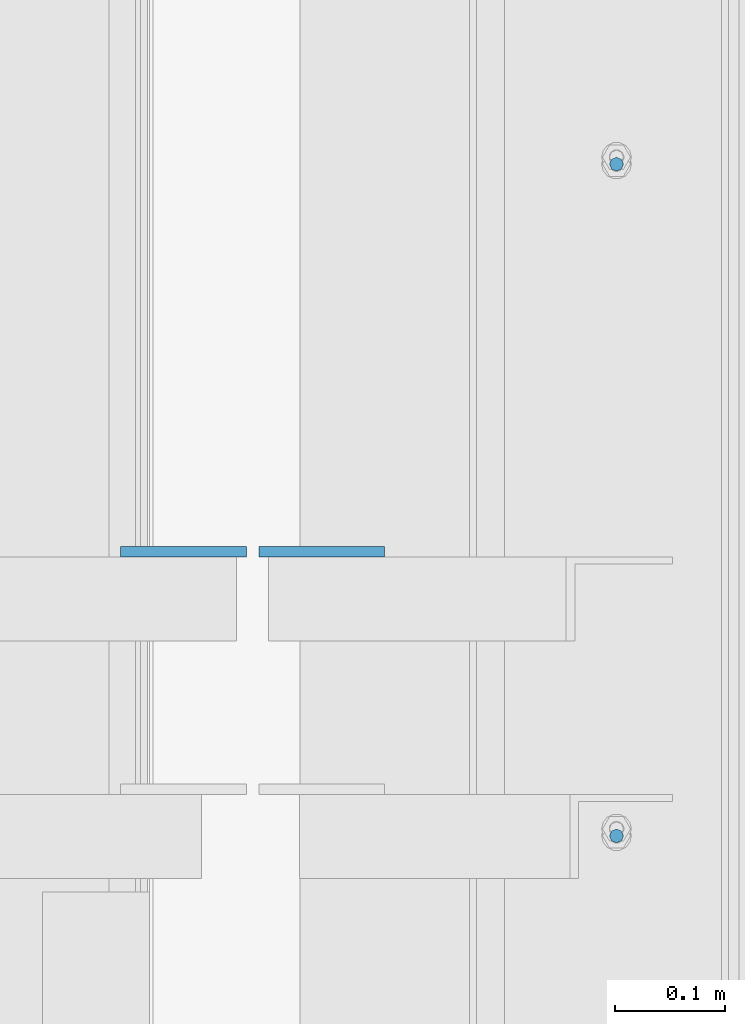
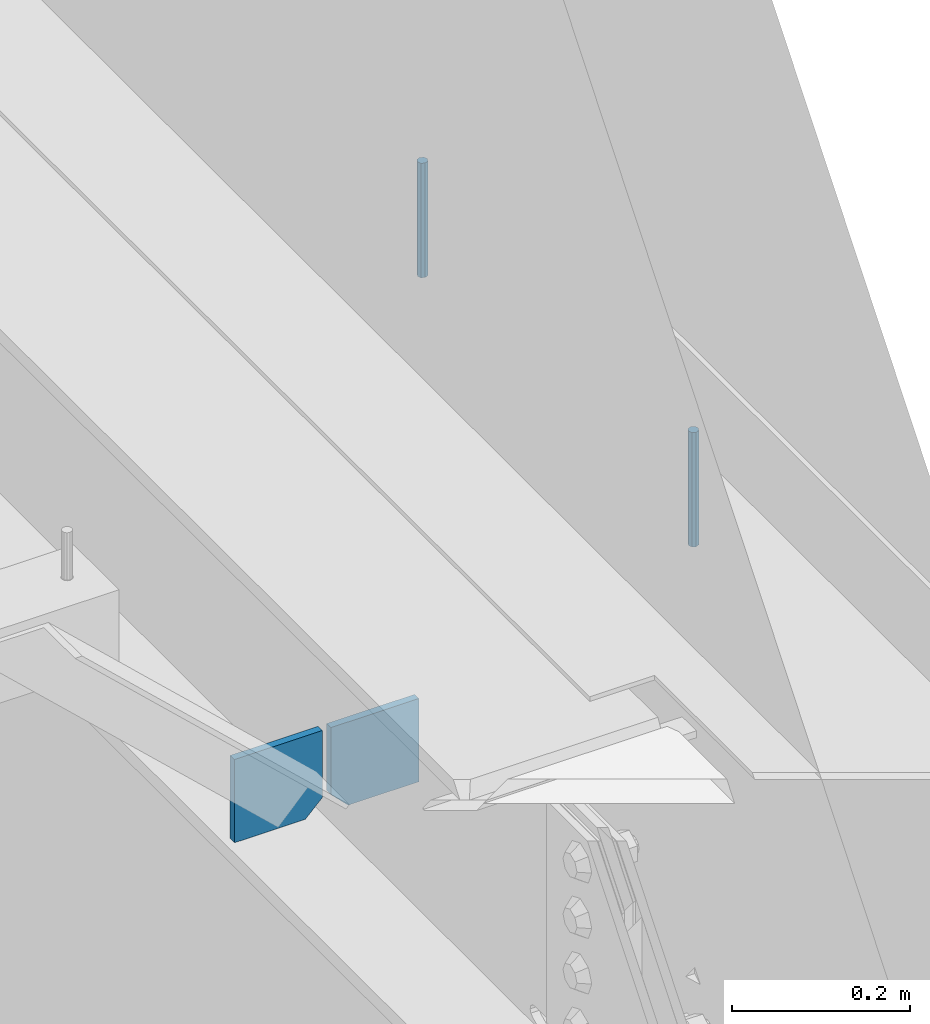
# One storey, part 471 of 1179: 4 columns, 1 element without a shape of its own.
"""IFC2X3 building model written with IfcOpenShell, lengths in millimetres."""

from ifc_helpers import new_model, si_unit, frame, origin_with_axes, place, context, subcontext, project, spatial, faceted_brep, material, type_object, element, aggregate, save


model = new_model("IFC2X3")

# Units and contexts
model_context = context("Model", 3, precision=1e-05, world=origin_with_axes())
body_context = subcontext(model_context, "Body", "Model", "MODEL_VIEW")
ifc_project = project(units=[si_unit("LENGTHUNIT", "METRE", prefix="MILLI"), si_unit("AREAUNIT", "SQUARE_METRE"), si_unit("VOLUMEUNIT", "CUBIC_METRE"), si_unit("MASSUNIT", "GRAM", prefix="KILO"), si_unit("TIMEUNIT", "SECOND"), si_unit("PLANEANGLEUNIT", "RADIAN"), si_unit("SOLIDANGLEUNIT", "STERADIAN"), si_unit("THERMODYNAMICTEMPERATUREUNIT", "DEGREE_CELSIUS"), si_unit("LUMINOUSINTENSITYUNIT", "LUMEN")], contexts=[model_context])

# Site, building, storey
site_placement = place(None, origin_with_axes())
site = spatial("IfcSite", under=ifc_project, at=site_placement, CompositionType="ELEMENT")
building_placement = place(site_placement, origin_with_axes())
building = spatial("IfcBuilding", under=site, at=building_placement, Name="Undefined", CompositionType="ELEMENT")
storey_placement = place(building_placement, origin_with_axes())
storey = spatial("IfcBuildingStorey", under=building, at=storey_placement, Name="Undefined", CompositionType="ELEMENT", Elevation=0.0)

# Assembly, columns
assembly_placement = place(storey_placement, origin_with_axes())
assembly = element("IfcElementAssembly", 1, at=assembly_placement, inside=storey, Name="BEAM", AssemblyPlace="NOTDEFINED", PredefinedType="RIGID_FRAME")
ifc_material_1 = material(Name="STEEL/A36")
column_type_1 = type_object("IfcColumnType", PredefinedType="NOTDEFINED")
column_1_placement = place(assembly_placement, frame((24245.09375, 28235.9541453824, 3702.05), z_axis=(1.0, 0.0, 0.0), x_axis=(0.0, 0.0, 1.0)))
column_1 = element("IfcColumn", 2, at=column_1_placement, type_object=column_type_1, material=ifc_material_1, Name="PLATE", context=body_context, shape_type="Brep", body=[
    faceted_brep([(22.2250000000004, 4.76250000000073, 57.1500000000015), (0.0, 4.76250000000073, 34.9249999999993), (0.0, -4.76250000000073, 34.9249999999993), (22.2250000000004, -4.76250000000073, 57.1500000000015), (114.300000000001, 4.76250000000073, 57.1500000000015), (114.300000000001, 4.76250000000073, -57.1500000000015), (0.0, 4.76250000000073, -57.1500000000015), (114.300000000001, -4.76250000000073, 57.1500000000015), (0.0, -4.76250000000073, -57.1500000000015), (114.300000000001, -4.76250000000073, -57.1500000000015)], [[[0, 1, 2, 3]], [[4, 5, 6, 1, 0]], [[7, 4, 0, 3]], [[8, 9, 7, 3, 2]], [[8, 6, 5, 9]], [[7, 9, 5, 4]], [[6, 8, 2, 1]]]),
])
column_2_placement = place(assembly_placement, frame((24370.50625, 28235.9541453824, 3702.05), z_axis=(-1.0, 0.0, 0.0), x_axis=(0.0, 0.0, 1.0)))
column_2 = element("IfcColumn", 3, at=column_2_placement, type_object=column_type_1, material=ifc_material_1, Name="PLATE", context=body_context, shape_type="Brep", body=[
    faceted_brep([(22.2250000000004, 4.76250000000073, 57.1500000000015), (0.0, 4.76250000000073, 34.9249999999993), (0.0, -4.76250000000073, 34.9249999999993), (22.2250000000004, -4.76250000000073, 57.1500000000015), (114.300000000001, 4.76250000000073, 57.1500000000015), (114.300000000001, 4.76250000000073, -57.1500000000015), (0.0, 4.76250000000073, -57.1500000000015), (114.300000000001, -4.76250000000073, 57.1500000000015), (0.0, -4.76250000000073, -57.1500000000015), (114.300000000001, -4.76250000000073, -57.1500000000015)], [[[0, 1, 2, 3]], [[4, 5, 6, 1, 0]], [[7, 4, 0, 3]], [[8, 9, 7, 3, 2]], [[8, 6, 5, 9]], [[7, 9, 5, 4]], [[6, 8, 2, 1]]]),
])
ifc_material_2 = material(Name="STEEL/A307")
column_type_2 = type_object("IfcColumnType", PredefinedType="NOTDEFINED")
column_3_placement = place(assembly_placement, frame((24638.0, 28587.70025, 4108.45), z_axis=(0.0, 1.0, 0.0), x_axis=(0.0, 0.0, 1.0)))
column_3 = element("IfcColumn", 4, at=column_3_placement, type_object=column_type_2, material=ifc_material_2, Name="THREADED ROD", context=body_context, shape_type="Brep", body=[
    faceted_brep([(0.0, -6.34999999999854, 0.0), (0.0, -4.49012806053361, -4.49012806053452), (157.162499999999, -4.49012806053361, -4.49012806053361), (157.162499999999, -6.34999999999854, 0.0), (0.0, 0.0, -6.34999999999991), (157.162499999999, 0.0, -6.34999999999854), (0.0, 4.49012806053361, -4.49012806053452), (157.162499999999, 4.49012806053361, -4.49012806053361), (0.0, 6.34999999999854, 0.0), (157.162499999999, 6.34999999999854, 0.0), (0.0, 4.49012806053361, 4.49012806053452), (157.162499999999, 4.49012806053361, 4.49012806053361), (0.0, 0.0, 6.34999999999991), (157.162499999999, 0.0, 6.34999999999854), (0.0, -4.49012806053361, 4.49012806053452), (157.162499999999, -4.49012806053361, 4.49012806053361)], [[[0, 1, 2, 3]], [[1, 4, 5, 2]], [[4, 6, 7, 5]], [[6, 8, 9, 7]], [[8, 10, 11, 9]], [[10, 12, 13, 11]], [[12, 14, 15, 13]], [[14, 0, 3, 15]], [[5, 7, 9, 11, 13, 15, 3, 2]], [[14, 12, 10, 8, 6, 4, 1, 0]]]),
])
column_4_placement = place(assembly_placement, frame((24638.0, 27978.10025, 4108.45), z_axis=(0.0, 1.0, 0.0), x_axis=(0.0, 0.0, 1.0)))
column_4 = element("IfcColumn", 5, at=column_4_placement, type_object=column_type_2, material=ifc_material_2, Name="THREADED ROD", context=body_context, shape_type="Brep", body=[
    faceted_brep([(0.0, -6.34999999999854, 0.0), (0.0, -4.49012806053361, -4.49012806053452), (157.162499999999, -4.49012806053361, -4.49012806053361), (157.162499999999, -6.34999999999854, 0.0), (0.0, 0.0, -6.34999999999991), (157.162499999999, 0.0, -6.34999999999854), (0.0, 4.49012806053361, -4.49012806053452), (157.162499999999, 4.49012806053361, -4.49012806053361), (0.0, 6.34999999999854, 0.0), (157.162499999999, 6.34999999999854, 0.0), (0.0, 4.49012806053361, 4.49012806053452), (157.162499999999, 4.49012806053361, 4.49012806053361), (0.0, 0.0, 6.34999999999991), (157.162499999999, 0.0, 6.34999999999854), (0.0, -4.49012806053361, 4.49012806053452), (157.162499999999, -4.49012806053361, 4.49012806053361)], [[[0, 1, 2, 3]], [[1, 4, 5, 2]], [[4, 6, 7, 5]], [[6, 8, 9, 7]], [[8, 10, 11, 9]], [[10, 12, 13, 11]], [[12, 14, 15, 13]], [[14, 0, 3, 15]], [[5, 7, 9, 11, 13, 15, 3, 2]], [[14, 12, 10, 8, 6, 4, 1, 0]]]),
])
aggregate(assembly, [column_3, column_4, column_1, column_2])

save(model, "model.ifc")
